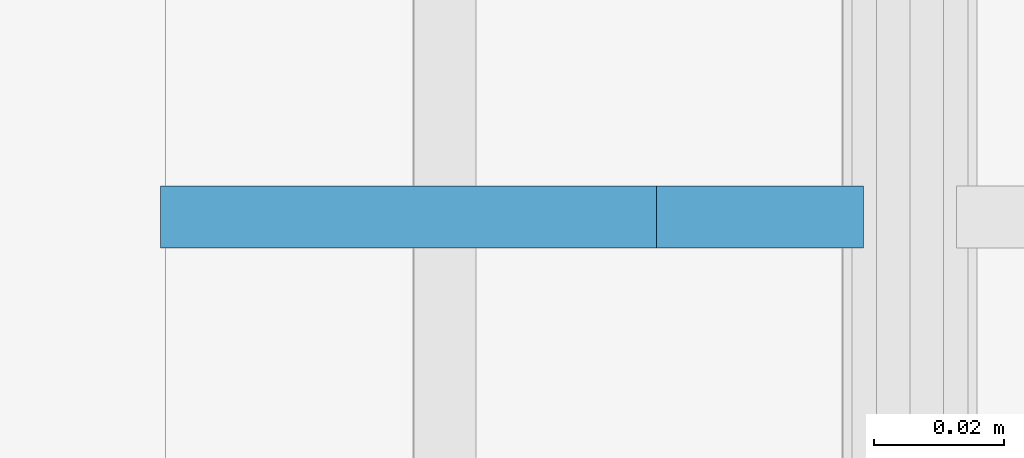
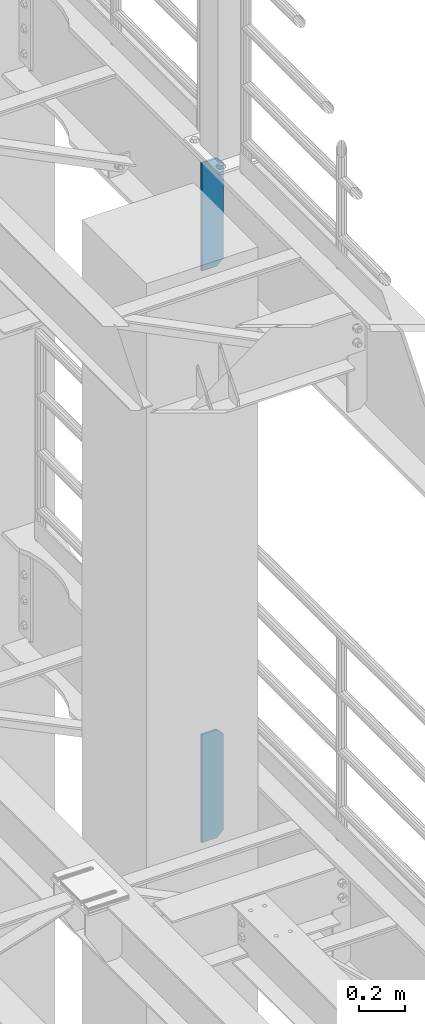
# One storey, part 1668 of 1876: 2 plates, 2 elements without a shape of their own.
"""IFC2X3 building model written with IfcOpenShell, lengths in millimetres."""

from ifc_helpers import new_model, si_unit, frame, origin_with_axes, place, context, subcontext, project, spatial, faceted_brep, material, type_object, element, aggregate, save


model = new_model("IFC2X3")

# Units and contexts
model_context = context("Model", 3, precision=1e-05, world=origin_with_axes())
body_context = subcontext(model_context, "Body", "Model", "MODEL_VIEW")
ifc_project = project(units=[si_unit("LENGTHUNIT", "METRE", prefix="MILLI"), si_unit("AREAUNIT", "SQUARE_METRE"), si_unit("VOLUMEUNIT", "CUBIC_METRE"), si_unit("MASSUNIT", "GRAM", prefix="KILO"), si_unit("TIMEUNIT", "SECOND"), si_unit("PLANEANGLEUNIT", "RADIAN"), si_unit("SOLIDANGLEUNIT", "STERADIAN"), si_unit("THERMODYNAMICTEMPERATUREUNIT", "DEGREE_CELSIUS"), si_unit("LUMINOUSINTENSITYUNIT", "LUMEN")], contexts=[model_context])

# Site, building, storey
site_placement = place(None, origin_with_axes())
site = spatial("IfcSite", under=ifc_project, at=site_placement, CompositionType="ELEMENT")
building_placement = place(site_placement, origin_with_axes())
building = spatial("IfcBuilding", under=site, at=building_placement, Name="Undefined", CompositionType="ELEMENT")
storey_placement = place(building_placement, origin_with_axes())
storey = spatial("IfcBuildingStorey", under=building, at=storey_placement, Name="Undefined", CompositionType="ELEMENT", Elevation=0.0)

# Assembly, plate
assembly_1_placement = place(storey_placement, origin_with_axes())
assembly_1 = element("IfcElementAssembly", 1, at=assembly_1_placement, inside=storey, Name="BEAM", AssemblyPlace="NOTDEFINED", PredefinedType="RIGID_FRAME")
ifc_material = material(Name="STEEL/A36")
plate_type = type_object("IfcPlateType", PredefinedType="NOTDEFINED")
plate_1_placement = place(assembly_1_placement, frame((7612.85625, 5588.0, 7556.5), z_axis=(0.0, 0.0, 1.0), x_axis=(-1.0, 0.0, 0.0)))
plate_1 = element("IfcPlate", 2, at=plate_1_placement, type_object=plate_type, material=ifc_material, Name="PLATE", context=body_context, shape_type="Brep", body=[
    faceted_brep([(-9.76996261670138e-14, -4.76250000000073, 31.75), (0.0, -4.76249999999982, 539.75), (0.0, 4.76249999999982, 539.75), (-9.76996261670138e-14, 4.76250000000073, 31.75), (31.75, -4.76249999999982, 571.5), (31.75, 4.76249999999982, 571.5), (107.949996948242, -4.76249999999982, 571.5), (107.949996948242, 4.76249999999982, 571.5), (107.950006484985, -4.76250000000073, 0.0), (107.950006484985, 4.76250000000073, 0.0), (31.75, -4.76250000000073, 0.0), (31.75, 4.76250000000073, 0.0)], [[[0, 1, 2, 3]], [[1, 4, 5, 2]], [[4, 6, 7, 5]], [[6, 8, 9, 7]], [[8, 10, 11, 9]], [[10, 0, 3, 11]], [[5, 7, 9, 11, 3, 2]], [[10, 8, 6, 4, 1, 0]]]),
])
aggregate(assembly_1, [plate_1])

assembly_2_placement = place(storey_placement, origin_with_axes())
assembly_2 = element("IfcElementAssembly", 3, at=assembly_2_placement, inside=storey, Name="BEAM", AssemblyPlace="NOTDEFINED", PredefinedType="RIGID_FRAME")
plate_2_placement = place(assembly_2_placement, frame((7612.85625, 5588.0, 4533.9), z_axis=(0.0, 0.0, 1.0), x_axis=(-1.0, 0.0, 0.0)))
plate_2 = element("IfcPlate", 4, at=plate_2_placement, type_object=plate_type, material=ifc_material, Name="PLATE", context=body_context, shape_type="Brep", body=[
    faceted_brep([(-9.76996261670138e-14, -4.76250000000073, 31.75), (0.0, -4.76249999999982, 539.75), (0.0, 4.76249999999982, 539.75), (-9.76996261670138e-14, 4.76250000000073, 31.75), (31.75, -4.76249999999982, 571.5), (31.75, 4.76249999999982, 571.5), (107.949996948242, -4.76249999999982, 571.5), (107.949996948242, 4.76249999999982, 571.5), (107.950006484985, -4.76250000000073, 0.0), (107.950006484985, 4.76250000000073, 0.0), (31.75, -4.76250000000073, 0.0), (31.75, 4.76250000000073, 0.0)], [[[0, 1, 2, 3]], [[1, 4, 5, 2]], [[4, 6, 7, 5]], [[6, 8, 9, 7]], [[8, 10, 11, 9]], [[10, 0, 3, 11]], [[5, 7, 9, 11, 3, 2]], [[10, 8, 6, 4, 1, 0]]]),
])
aggregate(assembly_2, [plate_2])

save(model, "model.ifc")
